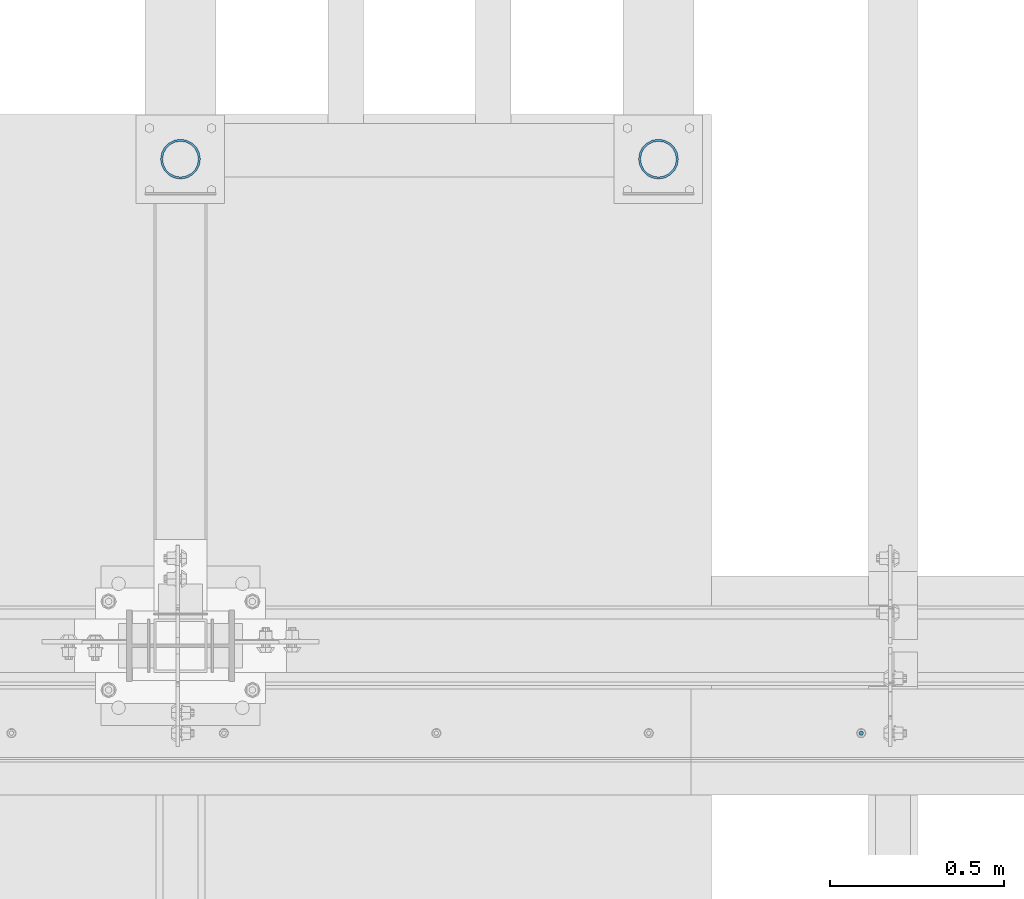
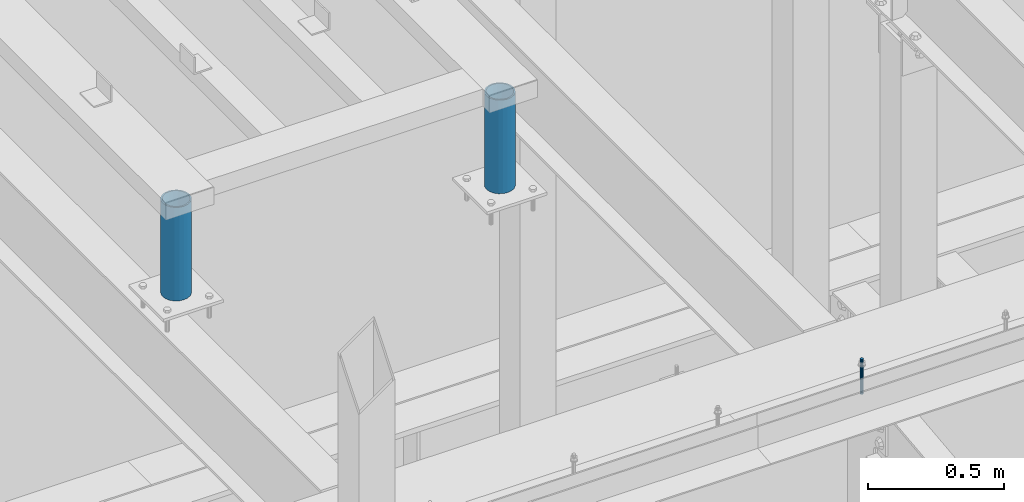
# One storey, part 501 of 1179: 3 columns, 2 elements without a shape of their own.
"""IFC2X3 building model written with IfcOpenShell, lengths in millimetres."""

from ifc_helpers import new_model, si_unit, frame, origin_with_axes, place, context, subcontext, project, spatial, faceted_brep, material, type_object, element, aggregate, save


model = new_model("IFC2X3")

# Units and contexts
model_context = context("Model", 3, precision=1e-05, world=origin_with_axes())
body_context = subcontext(model_context, "Body", "Model", "MODEL_VIEW")
ifc_project = project(units=[si_unit("LENGTHUNIT", "METRE", prefix="MILLI"), si_unit("AREAUNIT", "SQUARE_METRE"), si_unit("VOLUMEUNIT", "CUBIC_METRE"), si_unit("MASSUNIT", "GRAM", prefix="KILO"), si_unit("TIMEUNIT", "SECOND"), si_unit("PLANEANGLEUNIT", "RADIAN"), si_unit("SOLIDANGLEUNIT", "STERADIAN"), si_unit("THERMODYNAMICTEMPERATUREUNIT", "DEGREE_CELSIUS"), si_unit("LUMINOUSINTENSITYUNIT", "LUMEN")], contexts=[model_context])

# Site, building, storey
site_placement = place(None, origin_with_axes())
site = spatial("IfcSite", under=ifc_project, at=site_placement, CompositionType="ELEMENT")
building_placement = place(site_placement, origin_with_axes())
building = spatial("IfcBuilding", under=site, at=building_placement, Name="Undefined", CompositionType="ELEMENT")
storey_placement = place(building_placement, origin_with_axes())
storey = spatial("IfcBuildingStorey", under=building, at=storey_placement, Name="Undefined", CompositionType="ELEMENT", Elevation=0.0)

# Assembly, column
assembly_1_placement = place(storey_placement, origin_with_axes())
assembly_1 = element("IfcElementAssembly", 1, at=assembly_1_placement, inside=storey, Name="BEAM", AssemblyPlace="NOTDEFINED", PredefinedType="RIGID_FRAME")
ifc_material_1 = material(Name="STEEL/A307")
column_type_1 = type_object("IfcColumnType", PredefinedType="NOTDEFINED")
column_1_placement = place(assembly_1_placement, frame((10233.8187504082, 34140.775, 13125.45), z_axis=(0.0, 1.0, 0.0), x_axis=(0.0, 0.0, 1.0)))
column_1 = element("IfcColumn", 2, at=column_1_placement, type_object=column_type_1, material=ifc_material_1, Name="THREADED ROD", context=body_context, shape_type="Brep", body=[
    faceted_brep([(0.0, -6.34999999999854, 0.0), (0.0, -4.49012806053361, -4.49012806053452), (157.162499999999, -4.49012806053361, -4.49012806053361), (157.162499999999, -6.34999999999854, 0.0), (0.0, 0.0, -6.34999999999991), (157.162499999999, 0.0, -6.34999999999854), (0.0, 4.49012806053361, -4.49012806053452), (157.162499999999, 4.49012806053361, -4.49012806053361), (0.0, 6.34999999999854, 0.0), (157.162499999999, 6.34999999999854, 0.0), (0.0, 4.49012806053361, 4.49012806053452), (157.162499999999, 4.49012806053361, 4.49012806053361), (0.0, 0.0, 6.34999999999991), (157.162499999999, 0.0, 6.34999999999854), (0.0, -4.49012806053361, 4.49012806053452), (157.162499999999, -4.49012806053361, 4.49012806053361)], [[[0, 1, 2, 3]], [[1, 4, 5, 2]], [[4, 6, 7, 5]], [[6, 8, 9, 7]], [[8, 10, 11, 9]], [[10, 12, 13, 11]], [[12, 14, 15, 13]], [[14, 0, 3, 15]], [[5, 7, 9, 11, 13, 15, 3, 2]], [[14, 12, 10, 8, 6, 4, 1, 0]]]),
])
aggregate(assembly_1, [column_1])

# Assembly, columns
assembly_2_placement = place(storey_placement, origin_with_axes())
assembly_2 = element("IfcElementAssembly", 3, at=assembly_2_placement, inside=storey, Name="FRAME", AssemblyPlace="NOTDEFINED", PredefinedType="RIGID_FRAME")
ifc_material_2 = material()
column_type_2 = type_object("IfcColumnType", Name="PIPE4SCH40", PredefinedType="NOTDEFINED")
column_2_placement = place(assembly_2_placement, frame((9652.0, 35787.9344873485, 13265.15), z_axis=(0.0, 1.0, 0.0), x_axis=(0.0, 0.0, 1.0)))
column_2 = element("IfcColumn", 4, at=column_2_placement, type_object=column_type_2, material=ifc_material_2, Name="COLUMN", ObjectType="PIPE4SCH40", context=body_context, shape_type="Brep", body=[
    faceted_brep([(0.0, -51.1301999999996, 0.0), (0.0, -48.6277098894752, 15.8001007257917), (419.099999999999, -48.6277098894752, 15.8001007257917), (419.099999999999, -51.1301999999996, 0.0), (0.0, -41.3652007257915, 30.0535775067619), (419.099999999999, -41.3652007257915, 30.0535775067619), (0.0, -30.0535775067656, 41.3652007257915), (419.099999999999, -30.0535775067656, 41.3652007257915), (0.0, -15.8001007257917, 48.6277098894716), (419.099999999999, -15.8001007257917, 48.6277098894716), (0.0, 0.0, 51.1301999999996), (419.099999999999, 0.0, 51.1301999999996), (0.0, 15.8001007257917, 48.6277098894716), (419.099999999999, 15.8001007257917, 48.6277098894716), (0.0, 30.0535775067656, 41.3652007257915), (419.099999999999, 30.0535775067656, 41.3652007257915), (0.0, 41.3652007257915, 30.0535775067619), (419.099999999999, 41.3652007257915, 30.0535775067619), (0.0, 48.6277098894752, 15.8001007257917), (419.099999999999, 48.6277098894752, 15.8001007257917), (0.0, 51.1301999999996, 0.0), (419.099999999999, 51.1301999999996, 0.0), (0.0, 48.6277098894752, -15.8001007257917), (419.099999999999, 48.6277098894752, -15.8001007257917), (0.0, 41.3652007257915, -30.0535775067619), (419.099999999999, 41.3652007257915, -30.0535775067619), (0.0, 30.0535775067656, -41.3652007257915), (419.099999999999, 30.0535775067656, -41.3652007257915), (0.0, 15.8001007257917, -48.6277098894716), (419.099999999999, 15.8001007257917, -48.6277098894716), (0.0, 0.0, -51.1301999999996), (419.099999999999, 0.0, -51.1301999999996), (0.0, -15.8001007257917, -48.6277098894716), (419.099999999999, -15.8001007257917, -48.6277098894716), (0.0, -30.0535775067656, -41.3652007257915), (419.099999999999, -30.0535775067656, -41.3652007257915), (0.0, -41.3652007257915, -30.0535775067619), (419.099999999999, -41.3652007257915, -30.0535775067619), (0.0, -48.6277098894752, -15.8001007257917), (419.099999999999, -48.6277098894752, -15.8001007257917), (0.0, -57.1500000000015, 0.0), (0.0, -54.3528799062697, -17.6603212285263), (419.099999999999, -54.3528799062697, -17.6603212285263), (419.099999999999, -57.1500000000015, 0.0), (0.0, -46.235321228527, -33.5919271685125), (419.099999999999, -46.235321228527, -33.5919271685125), (0.0, -33.5919271685161, -46.2353212285307), (419.099999999999, -33.5919271685161, -46.2353212285307), (0.0, -17.6603212285299, -54.3528799062697), (419.099999999999, -17.6603212285299, -54.3528799062697), (0.0, 0.0, -57.1500000000015), (419.099999999999, 0.0, -57.1500000000015), (0.0, 17.6603212285299, -54.3528799062697), (419.099999999999, 17.6603212285299, -54.3528799062697), (0.0, 33.5919271685161, -46.2353212285307), (419.099999999999, 33.5919271685161, -46.2353212285307), (0.0, 46.235321228527, -33.5919271685125), (419.099999999999, 46.235321228527, -33.5919271685125), (0.0, 54.3528799062697, -17.6603212285263), (419.099999999999, 54.3528799062697, -17.6603212285263), (0.0, 57.1500000000015, 0.0), (419.099999999999, 57.1500000000015, 0.0), (0.0, 54.3528799062697, 17.6603212285263), (419.099999999999, 54.3528799062697, 17.6603212285263), (0.0, 46.235321228527, 33.5919271685125), (419.099999999999, 46.235321228527, 33.5919271685125), (0.0, 33.5919271685161, 46.2353212285307), (419.099999999999, 33.5919271685161, 46.2353212285307), (0.0, 17.6603212285299, 54.3528799062697), (419.099999999999, 17.6603212285299, 54.3528799062697), (0.0, 0.0, 57.1500000000015), (419.099999999999, 0.0, 57.1500000000015), (0.0, -17.6603212285299, 54.3528799062697), (419.099999999999, -17.6603212285299, 54.3528799062697), (0.0, -33.5919271685161, 46.2353212285307), (419.099999999999, -33.5919271685161, 46.2353212285307), (0.0, -46.235321228527, 33.5919271685125), (419.099999999999, -46.235321228527, 33.5919271685125), (0.0, -54.3528799062697, 17.6603212285263), (419.099999999999, -54.3528799062697, 17.6603212285263)], [[[0, 1, 2, 3]], [[1, 4, 5, 2]], [[4, 6, 7, 5]], [[6, 8, 9, 7]], [[8, 10, 11, 9]], [[10, 12, 13, 11]], [[12, 14, 15, 13]], [[14, 16, 17, 15]], [[16, 18, 19, 17]], [[18, 20, 21, 19]], [[20, 22, 23, 21]], [[22, 24, 25, 23]], [[24, 26, 27, 25]], [[26, 28, 29, 27]], [[28, 30, 31, 29]], [[30, 32, 33, 31]], [[32, 34, 35, 33]], [[34, 36, 37, 35]], [[36, 38, 39, 37]], [[38, 0, 3, 39]], [[40, 41, 42, 43]], [[41, 44, 45, 42]], [[44, 46, 47, 45]], [[46, 48, 49, 47]], [[48, 50, 51, 49]], [[50, 52, 53, 51]], [[52, 54, 55, 53]], [[54, 56, 57, 55]], [[56, 58, 59, 57]], [[58, 60, 61, 59]], [[60, 62, 63, 61]], [[62, 64, 65, 63]], [[64, 66, 67, 65]], [[66, 68, 69, 67]], [[68, 70, 71, 69]], [[70, 72, 73, 71]], [[72, 74, 75, 73]], [[74, 76, 77, 75]], [[76, 78, 79, 77]], [[78, 40, 43, 79]], [[45, 47, 49, 51, 53, 55, 57, 59, 61, 63, 65, 67, 69, 71, 73, 75, 77, 79, 43, 42], [5, 7, 9, 11, 13, 15, 17, 19, 21, 23, 25, 27, 29, 31, 33, 35, 37, 39, 3, 2]], [[78, 76, 74, 72, 70, 68, 66, 64, 62, 60, 58, 56, 54, 52, 50, 48, 46, 44, 41, 40], [38, 36, 34, 32, 30, 28, 26, 24, 22, 20, 18, 16, 14, 12, 10, 8, 6, 4, 1, 0]]]),
])
column_3_placement = place(assembly_2_placement, frame((8280.4, 35787.9344873485, 13265.15), z_axis=(0.0, 1.0, 0.0), x_axis=(0.0, 0.0, 1.0)))
column_3 = element("IfcColumn", 5, at=column_3_placement, type_object=column_type_2, material=ifc_material_2, Name="COLUMN", ObjectType="PIPE4SCH40", context=body_context, shape_type="Brep", body=[
    faceted_brep([(0.0, -51.1301999999996, 0.0), (0.0, -48.6277098894752, 15.8001007257917), (419.099999999999, -48.6277098894752, 15.8001007257917), (419.099999999999, -51.1301999999996, 0.0), (0.0, -41.3652007257915, 30.0535775067619), (419.099999999999, -41.3652007257915, 30.0535775067619), (0.0, -30.0535775067656, 41.3652007257915), (419.099999999999, -30.0535775067656, 41.3652007257915), (0.0, -15.8001007257917, 48.6277098894716), (419.099999999999, -15.8001007257917, 48.6277098894716), (0.0, 0.0, 51.1301999999996), (419.099999999999, 0.0, 51.1301999999996), (0.0, 15.8001007257917, 48.6277098894716), (419.099999999999, 15.8001007257917, 48.6277098894716), (0.0, 30.0535775067656, 41.3652007257915), (419.099999999999, 30.0535775067656, 41.3652007257915), (0.0, 41.3652007257915, 30.0535775067619), (419.099999999999, 41.3652007257915, 30.0535775067619), (0.0, 48.6277098894752, 15.8001007257917), (419.099999999999, 48.6277098894752, 15.8001007257917), (0.0, 51.1301999999996, 0.0), (419.099999999999, 51.1301999999996, 0.0), (0.0, 48.6277098894752, -15.8001007257917), (419.099999999999, 48.6277098894752, -15.8001007257917), (0.0, 41.3652007257915, -30.0535775067619), (419.099999999999, 41.3652007257915, -30.0535775067619), (0.0, 30.0535775067656, -41.3652007257915), (419.099999999999, 30.0535775067656, -41.3652007257915), (0.0, 15.8001007257917, -48.6277098894716), (419.099999999999, 15.8001007257917, -48.6277098894716), (0.0, 0.0, -51.1301999999996), (419.099999999999, 0.0, -51.1301999999996), (0.0, -15.8001007257917, -48.6277098894716), (419.099999999999, -15.8001007257917, -48.6277098894716), (0.0, -30.0535775067656, -41.3652007257915), (419.099999999999, -30.0535775067656, -41.3652007257915), (0.0, -41.3652007257915, -30.0535775067619), (419.099999999999, -41.3652007257915, -30.0535775067619), (0.0, -48.6277098894752, -15.8001007257917), (419.099999999999, -48.6277098894752, -15.8001007257917), (0.0, -57.1500000000015, 0.0), (0.0, -54.3528799062697, -17.6603212285263), (419.099999999999, -54.3528799062697, -17.6603212285263), (419.099999999999, -57.1500000000015, 0.0), (0.0, -46.235321228527, -33.5919271685125), (419.099999999999, -46.235321228527, -33.5919271685125), (0.0, -33.5919271685161, -46.2353212285307), (419.099999999999, -33.5919271685161, -46.2353212285307), (0.0, -17.6603212285299, -54.3528799062697), (419.099999999999, -17.6603212285299, -54.3528799062697), (0.0, 0.0, -57.1500000000015), (419.099999999999, 0.0, -57.1500000000015), (0.0, 17.6603212285299, -54.3528799062697), (419.099999999999, 17.6603212285299, -54.3528799062697), (0.0, 33.5919271685161, -46.2353212285307), (419.099999999999, 33.5919271685161, -46.2353212285307), (0.0, 46.235321228527, -33.5919271685125), (419.099999999999, 46.235321228527, -33.5919271685125), (0.0, 54.3528799062697, -17.6603212285263), (419.099999999999, 54.3528799062697, -17.6603212285263), (0.0, 57.1500000000015, 0.0), (419.099999999999, 57.1500000000015, 0.0), (0.0, 54.3528799062697, 17.6603212285263), (419.099999999999, 54.3528799062697, 17.6603212285263), (0.0, 46.235321228527, 33.5919271685125), (419.099999999999, 46.235321228527, 33.5919271685125), (0.0, 33.5919271685161, 46.2353212285307), (419.099999999999, 33.5919271685161, 46.2353212285307), (0.0, 17.6603212285299, 54.3528799062697), (419.099999999999, 17.6603212285299, 54.3528799062697), (0.0, 0.0, 57.1500000000015), (419.099999999999, 0.0, 57.1500000000015), (0.0, -17.6603212285299, 54.3528799062697), (419.099999999999, -17.6603212285299, 54.3528799062697), (0.0, -33.5919271685161, 46.2353212285307), (419.099999999999, -33.5919271685161, 46.2353212285307), (0.0, -46.235321228527, 33.5919271685125), (419.099999999999, -46.235321228527, 33.5919271685125), (0.0, -54.3528799062697, 17.6603212285263), (419.099999999999, -54.3528799062697, 17.6603212285263)], [[[0, 1, 2, 3]], [[1, 4, 5, 2]], [[4, 6, 7, 5]], [[6, 8, 9, 7]], [[8, 10, 11, 9]], [[10, 12, 13, 11]], [[12, 14, 15, 13]], [[14, 16, 17, 15]], [[16, 18, 19, 17]], [[18, 20, 21, 19]], [[20, 22, 23, 21]], [[22, 24, 25, 23]], [[24, 26, 27, 25]], [[26, 28, 29, 27]], [[28, 30, 31, 29]], [[30, 32, 33, 31]], [[32, 34, 35, 33]], [[34, 36, 37, 35]], [[36, 38, 39, 37]], [[38, 0, 3, 39]], [[40, 41, 42, 43]], [[41, 44, 45, 42]], [[44, 46, 47, 45]], [[46, 48, 49, 47]], [[48, 50, 51, 49]], [[50, 52, 53, 51]], [[52, 54, 55, 53]], [[54, 56, 57, 55]], [[56, 58, 59, 57]], [[58, 60, 61, 59]], [[60, 62, 63, 61]], [[62, 64, 65, 63]], [[64, 66, 67, 65]], [[66, 68, 69, 67]], [[68, 70, 71, 69]], [[70, 72, 73, 71]], [[72, 74, 75, 73]], [[74, 76, 77, 75]], [[76, 78, 79, 77]], [[78, 40, 43, 79]], [[45, 47, 49, 51, 53, 55, 57, 59, 61, 63, 65, 67, 69, 71, 73, 75, 77, 79, 43, 42], [5, 7, 9, 11, 13, 15, 17, 19, 21, 23, 25, 27, 29, 31, 33, 35, 37, 39, 3, 2]], [[78, 76, 74, 72, 70, 68, 66, 64, 62, 60, 58, 56, 54, 52, 50, 48, 46, 44, 41, 40], [38, 36, 34, 32, 30, 28, 26, 24, 22, 20, 18, 16, 14, 12, 10, 8, 6, 4, 1, 0]]]),
])
aggregate(assembly_2, [column_2, column_3])

save(model, "model.ifc")
